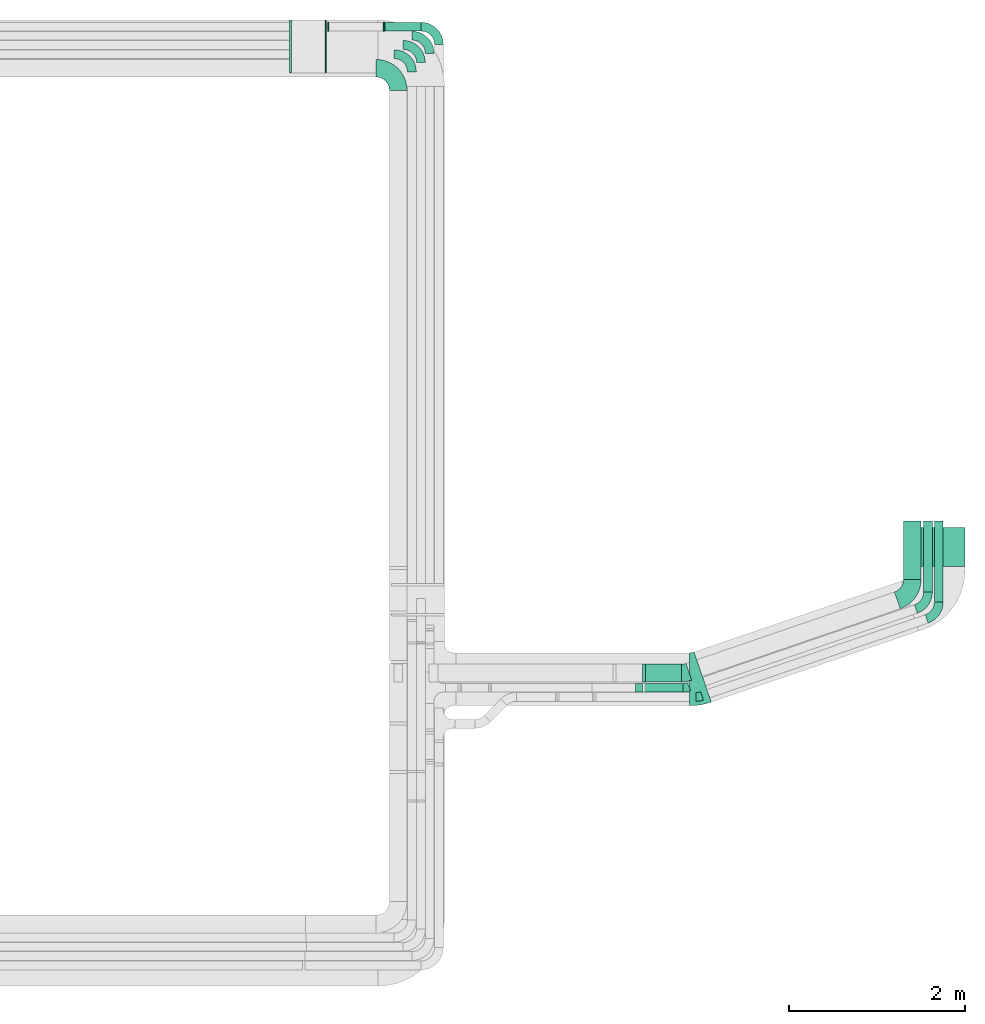
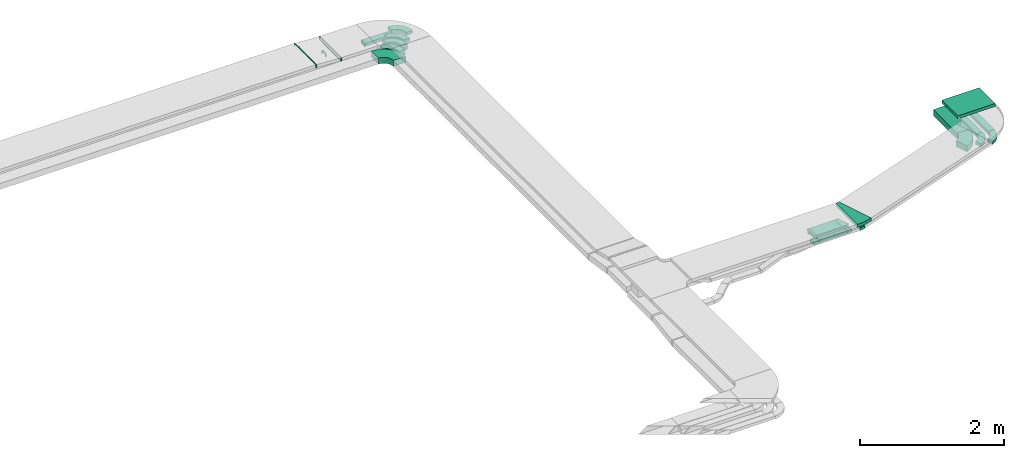
# One storey, part 24 of 28: 17 flow fittings, 8 flow segments.
"""IFC2X3 building model written with IfcOpenShell, lengths in millimetres."""

import ifcopenshell
import ifcopenshell.guid

model = None  # the IFC model being written
_history = None  # IfcOwnerHistory: only IFC2X3 demands one
_inside = {}  # id of a spatial element -> (the spatial element, [elements in it])
_under = {}  # id of a project, library or spatial element -> (it, [spatial elements below it])
_declared = {}  # id of a project -> (the project, [libraries it declares])
_typed = {}  # id of a type object -> (the type object, [elements of that type])
_made_of = {}  # id of a material, layer set ... -> (it, [elements and type objects made of it])


def new_model(schema):
    """Start an empty IFC model of exactly this schema.

    Asked for "IFC4X3", IfcOpenShell would pick the latest addendum, in which some entities
    have other attributes; the version numbers below select the first issue.
    IFC2X3 requires an IfcOwnerHistory on every rooted entity: one is made here for all.
    """
    global model, _history
    if schema == "IFC4X3":
        model = ifcopenshell.file(schema_version=(4, 3, 0, 0))
    else:
        model = ifcopenshell.file(schema=schema)
    _inside.clear()
    _under.clear()
    _declared.clear()
    _typed.clear()
    _made_of.clear()
    _history = None
    if model.schema == "IFC2X3":
        org = make("IfcOrganization", Name="unknown")
        user = make(
            "IfcPersonAndOrganization",
            ThePerson=make("IfcPerson", FamilyName="unknown"),
            TheOrganization=org,
        )
        app = make(
            "IfcApplication",
            ApplicationDeveloper=org,
            Version="unknown",
            ApplicationFullName="unknown",
            ApplicationIdentifier="unknown",
        )
        _history = make(
            "IfcOwnerHistory",
            OwningUser=user,
            OwningApplication=app,
            ChangeAction="ADDED",
            CreationDate=0,
        )
    return model


def make(cls, **values):
    """One entity of the class cls with the attributes given. An attribute that is None is left unset."""
    return model.create_entity(
        cls, **{name: value for name, value in values.items() if value is not None}
    )


def entity(cls, *values):
    """Any entity or typed value of the class cls, its attributes in the order of the schema. None: left unset."""
    e = model.create_entity(cls)
    for i, value in enumerate(values):
        if value is not None:
            e[i] = value
    return e


def rooted(cls, **values):
    """An entity with a GlobalId (a new one), such as an element, a storey or a relation."""
    return make(cls, GlobalId=ifcopenshell.guid.new(), OwnerHistory=_history, **values)


def si_unit(unit_type, name, prefix=None):
    """IfcSIUnit, for example si_unit("LENGTHUNIT", "METRE", prefix="MILLI")."""
    return make("IfcSIUnit", UnitType=unit_type, Prefix=prefix, Name=name)


def converted_unit(unit_type, name, factor, base, dimensions=None, offset=None):
    """IfcConversionBasedUnit, such as the inch: factor (a typed value) times the base unit."""
    return make(
        "IfcConversionBasedUnit"
        if offset is None
        else "IfcConversionBasedUnitWithOffset",
        ConversionOffset=offset,
        Dimensions=None
        if dimensions is None
        else entity("IfcDimensionalExponents", *dimensions),
        UnitType=unit_type,
        Name=name,
        ConversionFactor=make(
            "IfcMeasureWithUnit", ValueComponent=factor, UnitComponent=base
        ),
    )


def derived_unit(unit_type, elements):
    """IfcDerivedUnit: a product of units, each with its exponent."""
    return make(
        "IfcDerivedUnit",
        Elements=[
            make("IfcDerivedUnitElement", Unit=unit, Exponent=power)
            for unit, power in elements
        ],
        UnitType=unit_type,
    )


def assignment(units):
    """IfcUnitAssignment: the units of a project."""
    return None if units is None else make("IfcUnitAssignment", Units=units)


def point(xyz):
    """IfcCartesianPoint."""
    return None if xyz is None else make("IfcCartesianPoint", Coordinates=xyz)


def direction(xyz):
    """IfcDirection."""
    return None if xyz is None else make("IfcDirection", DirectionRatios=xyz)


def frame(location, z_axis=None, x_axis=None):
    """IfcAxis2Placement3D, a coordinate frame: its origin and axes. An axis left out is left unset."""
    return make(
        "IfcAxis2Placement3D",
        Location=point(location),
        Axis=direction(z_axis),
        RefDirection=direction(x_axis),
    )


def frame_2d(location, x_axis=None):
    """IfcAxis2Placement2D, a coordinate frame in the plane: its origin and x axis."""
    return make(
        "IfcAxis2Placement2D", Location=point(location), RefDirection=direction(x_axis)
    )


def origin():
    """The frame at (0, 0, 0) with its axes left unset."""
    return frame((0.0, 0.0, 0.0))


def origin_2d_with_axis():
    """The frame at (0, 0) in the plane with the x axis (1, 0) written out."""
    return frame_2d((0.0, 0.0), x_axis=(1.0, 0.0))


def place(relative_to, where):
    """IfcLocalPlacement: puts the frame where relative to a parent placement (None: the world)."""
    return make(
        "IfcLocalPlacement", PlacementRelTo=relative_to, RelativePlacement=where
    )


def context(
    kind, dimensions, precision=None, world=None, true_north=None, identifier=None
):
    """IfcGeometricRepresentationContext, for example the 3D "Model" context."""
    return make(
        "IfcGeometricRepresentationContext",
        ContextIdentifier=identifier,
        ContextType=kind,
        CoordinateSpaceDimension=dimensions,
        Precision=precision,
        WorldCoordinateSystem=world,
        TrueNorth=true_north,
    )


def subcontext(parent, identifier, kind, view, scale=None):
    """IfcGeometricRepresentationSubContext, for example "Body" below "Model"."""
    return make(
        "IfcGeometricRepresentationSubContext",
        ContextIdentifier=identifier,
        ContextType=kind,
        ParentContext=parent,
        TargetScale=scale,
        TargetView=view,
    )


def project(units=None, contexts=None):
    """IfcProject with its units and contexts."""
    return rooted(
        "IfcProject",
        Name="project",
        RepresentationContexts=contexts,
        UnitsInContext=assignment(units),
    )


def spatial(cls, under=None, at=None, **own):
    """A site, building, storey or space (cls), placed at a placement, below another one or the project."""
    s = rooted(cls, ObjectPlacement=at, **own)
    if under is not None:
        _under.setdefault(under.id(), (under, []))[1].append(s)
    return s


def polyline(points):
    """IfcPolyline through the points."""
    return make("IfcPolyline", Points=[point(p) for p in points])


def circle_curve(where, radius):
    """IfcCircle in the frame where."""
    return make("IfcCircle", Position=where, Radius=radius)


def parameter(value):
    """IfcParameterValue: where a trimmed curve begins or ends, as a parameter of its basis curve."""
    return model.create_entity("IfcParameterValue", value)


def trimmed(basis, trim1, trim2, sense, master):
    """IfcTrimmedCurve: the piece of a basis curve between two trims."""
    return make(
        "IfcTrimmedCurve",
        BasisCurve=basis,
        Trim1=trim1,
        Trim2=trim2,
        SenseAgreement=sense,
        MasterRepresentation=master,
    )


def segment(curve, same_sense, transition):
    """IfcCompositeCurveSegment."""
    return make(
        "IfcCompositeCurveSegment",
        Transition=transition,
        SameSense=same_sense,
        ParentCurve=curve,
    )


def composite_curve(segments, self_intersect=None):
    """IfcCompositeCurve: segments joined end to end."""
    return make("IfcCompositeCurve", Segments=segments, SelfIntersect=self_intersect)


def profile(cls, at=None, kind="AREA", **sizes):
    """A parametric profile (cls). Its sizes go by their IFC names, for example OverallWidth=200.0."""
    return make(cls, ProfileType=kind, Position=at, **sizes)


def rectangle(**sizes):
    """IfcRectangleProfileDef."""
    return profile("IfcRectangleProfileDef", **sizes)


def outline(outer, holes=None, kind="AREA"):
    """IfcArbitraryClosedProfileDef: a profile drawn as a closed curve; with holes, ...WithVoids."""
    if holes is None:
        return make("IfcArbitraryClosedProfileDef", ProfileType=kind, OuterCurve=outer)
    return make(
        "IfcArbitraryProfileDefWithVoids",
        ProfileType=kind,
        OuterCurve=outer,
        InnerCurves=holes,
    )


def extrude(swept, where, along, depth):
    """IfcExtrudedAreaSolid: the profile swept, set in the frame where, extruded along a direction by depth."""
    return make(
        "IfcExtrudedAreaSolid",
        SweptArea=swept,
        Position=where,
        ExtrudedDirection=direction(along),
        Depth=depth,
    )


def faces_of(points, faces, orient=None, outer=None):
    """IfcFace entities. A face is a list of loops; a loop is a list of indices into points, from 0.

    orient and outer hold one flag for each loop. By default every Orientation is true, the
    first loop of a face is its IfcFaceOuterBound and the others are IfcFaceBound.
    """
    made = []
    for i, loops in enumerate(faces):
        bounds = []
        for j, loop in enumerate(loops):
            is_outer = j == 0 if outer is None else outer[i][j]
            bounds.append(
                make(
                    "IfcFaceOuterBound" if is_outer else "IfcFaceBound",
                    Bound=make("IfcPolyLoop", Polygon=[points[k] for k in loop]),
                    Orientation=True if orient is None else orient[i][j],
                )
            )
        made.append(make("IfcFace", Bounds=bounds))
    return made


def faceted_brep(points, faces, orient=None, outer=None, voids=None):
    """IfcFacetedBrep: a solid bounded by flat faces; with voids (closed shells), ...WithVoids."""
    shared = [point(p) for p in points]
    hull = make("IfcClosedShell", CfsFaces=faces_of(shared, faces, orient, outer))
    if voids is None:
        return make("IfcFacetedBrep", Outer=hull)
    return make(
        "IfcFacetedBrepWithVoids",
        Outer=hull,
        Voids=[
            make(cls, CfsFaces=faces_of(shared, fs, o, b)) for cls, fs, o, b in voids
        ],
    )


def shape(context_of_items, identifier, shape_type, items):
    """IfcShapeRepresentation: the items that make up one representation, for example the "Body"."""
    return make(
        "IfcShapeRepresentation",
        ContextOfItems=context_of_items,
        RepresentationIdentifier=identifier,
        RepresentationType=shape_type,
        Items=items,
    )


def source(mapping_origin, context_of_items, identifier, shape_type, items):
    """IfcRepresentationMap: a shape defined once, which mapped items show again and again."""
    return make(
        "IfcRepresentationMap",
        MappingOrigin=mapping_origin,
        MappedRepresentation=shape(context_of_items, identifier, shape_type, items),
    )


def transform(
    local_origin,
    x_axis=None,
    y_axis=None,
    z_axis=None,
    scale=None,
    scale2=None,
    scale3=None,
    uniform=True,
):
    """IfcCartesianTransformationOperator3D, or its non-uniform kind. x_axis, y_axis, z_axis: its Axis1, 2, 3."""
    if uniform:
        return make(
            "IfcCartesianTransformationOperator3D",
            Axis1=direction(x_axis),
            Axis2=direction(y_axis),
            LocalOrigin=point(local_origin),
            Scale=scale,
            Axis3=direction(z_axis),
        )
    return make(
        "IfcCartesianTransformationOperator3DnonUniform",
        Axis1=direction(x_axis),
        Axis2=direction(y_axis),
        LocalOrigin=point(local_origin),
        Scale=scale,
        Axis3=direction(z_axis),
        Scale2=scale2,
        Scale3=scale3,
    )


def mapped(mapping_source, mapping_target):
    """IfcMappedItem: shows the shape of a source again, moved by a transform."""
    return make(
        "IfcMappedItem", MappingSource=mapping_source, MappingTarget=mapping_target
    )


def material(Name=None, Category=None):
    """IfcMaterial."""
    return make("IfcMaterial", Name=Name, Category=Category)


def made_of(thing, what):
    """Note that an element or type object is made of a material, layer set ...; save() writes the relation."""
    if what is not None:
        _made_of.setdefault(what.id(), (what, []))[1].append(thing)
    return thing


def type_object(cls, material=None, **own):
    """A type object (cls), such as IfcWallType, which elements share."""
    return made_of(rooted(cls, **own), material)


def type_shapes(of_type, sources):
    """Give a type object the sources (RepresentationMaps) that its elements show as mapped items."""
    of_type.RepresentationMaps = sources


def element(
    cls,
    number,
    at=None,
    inside=None,
    cuts=None,
    type_object=None,
    material=None,
    context=None,
    identifier="Body",
    shape_type=None,
    held_by="IfcProductDefinitionShape",
    body=None,
    shapes=None,
    **own,
):
    """One element of the class cls, such as IfcWall. Its Tag is "e" and its number.

    at: its placement. inside: the storey or other place that contains it. cuts: it is an
    opening in that element (IfcRelVoidsElement). A single representation is given by context,
    identifier, shape_type and body (its items); several are given by shapes. held_by: the class
    of the entity that holds the representations. save() writes the other relations.
    """
    e = rooted(cls, Tag="e%d" % number, ObjectPlacement=at, **own)
    if body is not None:
        shapes = [shape(context, identifier, shape_type, body)]
    if shapes is not None:
        e.Representation = make(held_by, Representations=shapes)
    if inside is not None:
        _inside.setdefault(inside.id(), (inside, []))[1].append(e)
    if cuts is not None:
        rooted(
            "IfcRelVoidsElement", RelatingBuildingElement=cuts, RelatedOpeningElement=e
        )
    if type_object is not None:
        _typed.setdefault(type_object.id(), (type_object, []))[1].append(e)
    return made_of(e, material)


def aggregate(whole, parts):
    """IfcRelAggregates: a whole, such as a stair, and the parts it consists of."""
    return rooted("IfcRelAggregates", RelatingObject=whole, RelatedObjects=parts)


def save(model, path):
    """Write the relations noted so far, then the file.

    IfcRelAggregates (storeys below a building ...), IfcRelContainedInSpatialStructure (elements
    in a storey), IfcRelDefinesByType, IfcRelAssociatesMaterial and IfcRelDeclares: one each for
    every whole, place, type object, material and project.
    """
    for whole, parts in _under.values():
        aggregate(whole, parts)
    for where, things in _inside.values():
        rooted(
            "IfcRelContainedInSpatialStructure",
            RelatedElements=things,
            RelatingStructure=where,
        )
    for kind, things in _typed.values():
        rooted("IfcRelDefinesByType", RelatedObjects=things, RelatingType=kind)
    for what, things in _made_of.values():
        rooted("IfcRelAssociatesMaterial", RelatedObjects=things, RelatingMaterial=what)
    for by, libraries in _declared.values():
        rooted("IfcRelDeclares", RelatingContext=by, RelatedDefinitions=libraries)
    model.write(path)


model = new_model("IFC2X3")

# Units and contexts
model_context = context("Model", 3, precision=0.01, world=origin(), true_north=direction((6.12303176911189e-17, 1.0)))
body_context = subcontext(model_context, "Body", "Model", "MODEL_VIEW")
ifc_project = project(units=[si_unit("LENGTHUNIT", "METRE", prefix="MILLI"), si_unit("AREAUNIT", "SQUARE_METRE"), si_unit("VOLUMEUNIT", "CUBIC_METRE"), converted_unit("PLANEANGLEUNIT", "DEGREE", entity("IfcRatioMeasure", 0.0174532925199433), si_unit("PLANEANGLEUNIT", "RADIAN"), dimensions=[0, 0, 0, 0, 0, 0, 0]), si_unit("MASSUNIT", "GRAM", prefix="KILO"), derived_unit("MASSDENSITYUNIT", [(si_unit("MASSUNIT", "GRAM", prefix="KILO"), 1), (si_unit("LENGTHUNIT", "METRE"), -3)]), derived_unit("MOMENTOFINERTIAUNIT", [(si_unit("LENGTHUNIT", "METRE"), 4)]), si_unit("TIMEUNIT", "SECOND"), si_unit("FREQUENCYUNIT", "HERTZ"), si_unit("THERMODYNAMICTEMPERATUREUNIT", "DEGREE_CELSIUS"), derived_unit("THERMALTRANSMITTANCEUNIT", [(si_unit("MASSUNIT", "GRAM", prefix="KILO"), 1), (si_unit("THERMODYNAMICTEMPERATUREUNIT", "KELVIN"), -1), (si_unit("TIMEUNIT", "SECOND"), -3)]), derived_unit("VOLUMETRICFLOWRATEUNIT", [(si_unit("LENGTHUNIT", "METRE"), 3), (si_unit("TIMEUNIT", "SECOND"), -1)]), derived_unit("MASSFLOWRATEUNIT", [(si_unit("MASSUNIT", "GRAM", prefix="KILO"), 1), (si_unit("TIMEUNIT", "SECOND"), -1)]), derived_unit("ROTATIONALFREQUENCYUNIT", [(si_unit("TIMEUNIT", "SECOND"), -1)]), si_unit("ELECTRICCURRENTUNIT", "AMPERE"), si_unit("ELECTRICVOLTAGEUNIT", "VOLT"), si_unit("POWERUNIT", "WATT"), si_unit("FORCEUNIT", "NEWTON", prefix="KILO"), si_unit("ILLUMINANCEUNIT", "LUX"), si_unit("LUMINOUSFLUXUNIT", "LUMEN"), si_unit("LUMINOUSINTENSITYUNIT", "CANDELA"), derived_unit("USERDEFINED", [(si_unit("MASSUNIT", "GRAM", prefix="KILO"), -1), (si_unit("LENGTHUNIT", "METRE"), -2), (si_unit("TIMEUNIT", "SECOND"), 3), (si_unit("LUMINOUSFLUXUNIT", "LUMEN"), 1)]), derived_unit("LINEARVELOCITYUNIT", [(si_unit("LENGTHUNIT", "METRE"), 1), (si_unit("TIMEUNIT", "SECOND"), -1)]), si_unit("PRESSUREUNIT", "PASCAL"), derived_unit("USERDEFINED", [(si_unit("LENGTHUNIT", "METRE"), -2), (si_unit("MASSUNIT", "GRAM", prefix="KILO"), 1), (si_unit("TIMEUNIT", "SECOND"), -2)]), derived_unit("LINEARFORCEUNIT", [(si_unit("MASSUNIT", "GRAM", prefix="KILO"), 1), (si_unit("LENGTHUNIT", "METRE"), 1), (si_unit("TIMEUNIT", "SECOND"), -2), (si_unit("LENGTHUNIT", "METRE"), -1)]), derived_unit("PLANARFORCEUNIT", [(si_unit("MASSUNIT", "GRAM", prefix="KILO"), 1), (si_unit("LENGTHUNIT", "METRE"), 1), (si_unit("TIMEUNIT", "SECOND"), -2), (si_unit("LENGTHUNIT", "METRE"), -2)])], contexts=[model_context])

# Site, building, storey
site_placement = place(None, origin())
site = spatial("IfcSite", under=ifc_project, at=site_placement, CompositionType="ELEMENT")
building_placement = place(site_placement, origin())
building = spatial("IfcBuilding", under=site, at=building_placement, CompositionType="ELEMENT")
storey_placement = place(building_placement, frame((0.0, 0.0, 4200.0)))
storey = spatial("IfcBuildingStorey", under=building, at=storey_placement, CompositionType="ELEMENT", Elevation=4200.0)

# Flow segments
cable_carrier_segment_type = type_object("IfcCableCarrierSegmentType", PredefinedType="CABLETRAYSEGMENT")
flow_segment_1_placement = place(storey_placement, frame((67394.03, 9970.3, 2859.5)))
element("IfcFlowSegment", 1, at=flow_segment_1_placement, inside=storey, type_object=cable_carrier_segment_type, context=body_context, shape_type="SweptSolid", body=[
    extrude(rectangle(XDim=443.027180218431, YDim=600.000000000002, at=origin_2d_with_axis()), frame((300.0, 221.51, 0.0), z_axis=(0.0, 0.0, 1.0), x_axis=(0.0, 1.0, 0.0)), (0.0, 0.0, 1.0), 50.0000000000005),
])
flow_segment_2_placement = place(storey_placement, frame((61417.21, 16039.18, 2500.0)))
element("IfcFlowSegment", 2, at=flow_segment_2_placement, inside=storey, type_object=cable_carrier_segment_type, context=body_context, shape_type="SweptSolid", body=[
    extrude(rectangle(XDim=422.974945905387, YDim=99.9999999999989, at=origin_2d_with_axis()), frame((211.49, 50.0, 0.0), z_axis=(0.0, 0.0, 1.0), x_axis=(-1.0, 0.0, 0.0)), (0.0, 0.0, 1.0), 49.9999999999995),
])
flow_segment_3_placement = place(storey_placement, frame((67298.26, 9825.03, 2637.16)))
element("IfcFlowSegment", 3, at=flow_segment_3_placement, inside=storey, type_object=cable_carrier_segment_type, context=body_context, shape_type="SweptSolid", body=[
    extrude(rectangle(XDim=660.390144086837, YDim=200.000000000007, at=origin_2d_with_axis()), frame((100.0, 330.2, 0.0), z_axis=(0.0, 0.0, 1.0), x_axis=(0.0, 1.0, 0.0)), (0.0, 0.0, 1.0), 99.9999999999978),
])
flow_segment_4_placement = place(storey_placement, frame((67525.83, 9680.21, 2683.28)))
element("IfcFlowSegment", 4, at=flow_segment_4_placement, inside=storey, type_object=cable_carrier_segment_type, context=body_context, shape_type="SweptSolid", body=[
    extrude(rectangle(XDim=805.217820192026, YDim=99.9999999999946, at=origin_2d_with_axis()), frame((50.0, 402.61, 0.0), z_axis=(0.0, 0.0, 1.0), x_axis=(0.0, 1.0, 0.0)), (0.0, 0.0, 1.0), 49.9999999999984),
])
flow_segment_5_placement = place(storey_placement, frame((67647.87, 9567.84, 2750.04)))
element("IfcFlowSegment", 5, at=flow_segment_5_placement, inside=storey, type_object=cable_carrier_segment_type, context=body_context, shape_type="SweptSolid", body=[
    extrude(rectangle(XDim=919.515278080052, YDim=99.9999999999426, at=origin_2d_with_axis()), frame((50.0, 459.76, 0.0), z_axis=(0.0, -1.12023218885433e-06, 1.0), x_axis=(0.0, 1.0, 1.12023218885433e-06)), (0.0, 0.0, 1.0), 49.999999999968),
])
flow_segment_6_placement = place(storey_placement, frame((64362.98, 8547.44, 2683.27)))
element("IfcFlowSegment", 6, at=flow_segment_6_placement, inside=storey, type_object=cable_carrier_segment_type, context=body_context, shape_type="SweptSolid", body=[
    extrude(rectangle(XDim=100.000000000001, YDim=438.35134819234, at=frame_2d((0.0, 0.0), x_axis=(0.0, 1.0))), frame((219.18, 50.01, 0.02), z_axis=(4.88705511740176e-05, -0.000142633733288134, 0.999999988633644), x_axis=(-1.0, 0.0, 4.88705516711381e-05)), (0.0, 0.0, 1.0), 50.0000000000004),
])
flow_segment_7_placement = place(storey_placement, frame((64374.07, 8663.79, 2637.16)))
element("IfcFlowSegment", 7, at=flow_segment_7_placement, inside=storey, type_object=cable_carrier_segment_type, context=body_context, shape_type="SweptSolid", body=[
    extrude(rectangle(XDim=408.398049155987, YDim=200.0, at=origin_2d_with_axis()), frame((204.2, 100.0, 0.0), z_axis=(0.0, 0.0, 1.0), x_axis=(-1.0, 0.0, 0.0)), (0.0, 0.0, 1.0), 99.9999999999989),
])
flow_segment_8_placement = place(storey_placement, frame((64258.91, 8547.45, 2669.22)))
element("IfcFlowSegment", 8, at=flow_segment_8_placement, inside=storey, type_object=cable_carrier_segment_type, context=body_context, shape_type="SweptSolid", body=[
    extrude(rectangle(XDim=49.9999999999996, YDim=82.6344223697702, at=frame_2d((0.0, 0.0), x_axis=(0.0, 1.0))), frame((44.72, 0.0, 31.16), z_axis=(0.0, 1.0, 0.0), x_axis=(-0.98768834059514, 0.0, -0.156434465040215)), (0.0, 0.0, 1.0), 100.000000000001),
])

# Flow fittings
ifc_material = material()
cable_carrier_fitting_type_1 = type_object("IfcCableCarrierFittingType", PredefinedType="NOTDEFINED", material=ifc_material)
shared_shape_1 = source(origin(), body_context, "Body", "Brep", [
    faceted_brep([(-6.7, -25.0, 300.0), (-6.7, 25.0, 300.0), (-6.7, 25.0, 297.46), (-6.7, -22.46, 297.46), (-6.7, -22.46, -297.46), (-6.7, 25.0, -297.46), (-6.7, 25.0, -300.0), (-6.7, -25.0, -300.0), (8.23, -24.54, 300.0), (8.23, -24.54, -300.0), (5.14, 25.37, -300.0), (5.14, 25.37, -297.46), (8.07, -22.0, -297.46), (8.07, -22.0, 297.46), (5.14, 25.37, 297.46), (5.14, 25.37, 300.0), (0.77, -25.0, 300.0), (-0.77, 25.0, 300.0), (-0.77, 25.0, 297.46), (0.69, -22.46, 297.46), (0.69, -22.46, -297.46), (-0.77, 25.0, -297.46), (-0.77, 25.0, -300.0), (0.77, -25.0, -300.0)], [[[0, 1, 2, 3, 4, 5, 6, 7]], [[8, 9, 10, 11, 12, 13, 14, 15]], [[1, 0, 16, 8, 15, 17]], [[2, 1, 17, 18]], [[3, 2, 18, 14, 13, 19]], [[4, 3, 19, 20]], [[5, 4, 20, 12, 11, 21]], [[6, 5, 21, 22]], [[7, 6, 22, 10, 9, 23]], [[0, 7, 23, 16]], [[18, 17, 15, 14]], [[20, 19, 13, 12]], [[22, 21, 11, 10]], [[16, 23, 9, 8]]]),
])
type_shapes(cable_carrier_fitting_type_1, [shared_shape_1])
for number, where, z_axis, x_axis in (
    (9, (60751.24, 15866.15, 2798.4), (0.0, 1.0, 0.0), (-1.0, 0.0, 0.0)),
    (10, (60350.54, 15866.15, 2823.17), (0.0, -1.0, 0.0), (-0.998094861417354, 0.0, 0.0616980357245895)),
):
    element("IfcFlowFitting", number, at=place(storey_placement, frame(where, z_axis=z_axis, x_axis=x_axis)), inside=storey, type_object=cable_carrier_fitting_type_1, material=ifc_material, context=body_context, shape_type="MappedRepresentation", body=[
        mapped(shared_shape_1, transform((0.0, 0.0, 0.0), scale=1.0)),
    ])
cable_carrier_fitting_type_2 = type_object("IfcCableCarrierFittingType", PredefinedType="NOTDEFINED", material=ifc_material)
shared_shape_2 = source(origin(), body_context, "Body", "Brep", [
    faceted_brep([(-13.26, -50.0, 100.0), (-13.26, 50.0, 100.0), (-13.26, 50.0, 97.46), (-13.26, -47.46, 97.46), (-13.26, -47.46, -97.46), (-13.26, 50.0, -97.46), (-13.26, 50.0, -100.0), (-13.26, -50.0, -100.0), (20.92, -47.31, 100.0), (20.92, -47.31, -100.0), (5.28, 51.46, -100.0), (5.28, 51.46, -97.46), (20.52, -44.8, -97.46), (20.52, -44.8, 97.46), (5.28, 51.46, 97.46), (5.28, 51.46, 100.0), (3.94, -50.0, 100.0), (-3.94, 50.0, 100.0), (-3.94, 50.0, 97.46), (3.74, -47.46, 97.46), (3.74, -47.46, -97.46), (-3.94, 50.0, -97.46), (-3.94, 50.0, -100.0), (3.94, -50.0, -100.0)], [[[0, 1, 2, 3, 4, 5, 6, 7]], [[8, 9, 10, 11, 12, 13, 14, 15]], [[1, 0, 16, 8, 15, 17]], [[2, 1, 17, 18]], [[3, 2, 18, 14, 13, 19]], [[4, 3, 19, 20]], [[5, 4, 20, 12, 11, 21]], [[6, 5, 21, 22]], [[7, 6, 22, 10, 9, 23]], [[0, 7, 23, 16]], [[18, 17, 15, 14]], [[20, 19, 13, 12]], [[22, 21, 11, 10]], [[16, 23, 9, 8]]]),
])
type_shapes(cable_carrier_fitting_type_2, [shared_shape_2])
flow_fitting_1_placement = place(storey_placement, frame((64360.81, 8763.79, 2687.16), z_axis=(0.0, -1.0, 0.0), x_axis=(-1.0, 0.0, 0.0)))
element("IfcFlowFitting", 11, at=flow_fitting_1_placement, inside=storey, type_object=cable_carrier_fitting_type_2, material=ifc_material, context=body_context, shape_type="MappedRepresentation", body=[
    mapped(shared_shape_2, transform((0.0, 0.0, 0.0), scale=1.0)),
])
cable_carrier_fitting_type_3 = type_object("IfcCableCarrierFittingType", PredefinedType="NOTDEFINED", material=ifc_material)
shared_shape_3 = source(origin(), body_context, "Body", "Brep", [
    faceted_brep([(-7.03, -25.0, 50.0), (-7.03, 25.0, 50.0), (-7.03, 25.0, 47.46), (-7.03, -22.46, 47.46), (-7.03, -22.46, -47.46), (-7.03, 25.0, -47.46), (-7.03, 25.0, -50.0), (-7.03, -25.0, -50.0), (8.84, -24.42, 50.0), (8.84, -24.42, -50.0), (5.17, 25.45, -50.0), (5.17, 25.45, -47.46), (8.66, -21.88, -47.46), (8.66, -21.88, 47.46), (5.17, 25.45, 47.46), (5.17, 25.45, 50.0), (0.92, -25.0, 50.0), (-0.92, 25.0, 50.0), (-0.92, 25.0, 47.46), (0.83, -22.46, 47.46), (0.83, -22.46, -47.46), (-0.92, 25.0, -47.46), (-0.92, 25.0, -50.0), (0.92, -25.0, -50.0)], [[[0, 1, 2, 3, 4, 5, 6, 7]], [[8, 9, 10, 11, 12, 13, 14, 15]], [[1, 0, 16, 8, 15, 17]], [[2, 1, 17, 18]], [[3, 2, 18, 14, 13, 19]], [[4, 3, 19, 20]], [[5, 4, 20, 12, 11, 21]], [[6, 5, 21, 22]], [[7, 6, 22, 10, 9, 23]], [[0, 7, 23, 16]], [[18, 17, 15, 14]], [[20, 19, 13, 12]], [[22, 21, 11, 10]], [[16, 23, 9, 8]]]),
])
type_shapes(cable_carrier_fitting_type_3, [shared_shape_3])
for number, where, z_axis, x_axis in (
    (12, (60776.78, 16089.18, 2571.71), (0.0, 1.0, 0.0), (1.0, 0.0, 0.0)),
    (13, (61410.18, 16089.18, 2525.0), (0.0, 1.0, 0.0), (-1.0, 0.0, 0.0)),
):
    element("IfcFlowFitting", number, at=place(storey_placement, frame(where, z_axis=z_axis, x_axis=x_axis)), inside=storey, type_object=cable_carrier_fitting_type_3, material=ifc_material, context=body_context, shape_type="MappedRepresentation", body=[
        mapped(shared_shape_3, transform((0.0, 0.0, 0.0), scale=1.0)),
    ])
cable_carrier_fitting_type_4 = type_object("IfcCableCarrierFittingType", Name="470_DKC_S5_Variable Angle Elbow 0-45:-", PredefinedType="NOTDEFINED", material=ifc_material)
shared_shape_4 = source(origin(), body_context, "Body", "SweptSolid", [
    extrude(outline(composite_curve([segment(polyline([(-125.75, -225.25), (-124.75, -225.25)]), True, "CONTINUOUS"), segment(trimmed(circle_curve(frame_2d((-124.75, 124.75), x_axis=(0.0, -1.0)), 350.0), [parameter(0.0)], [parameter(90.0000000000001)], True, "PARAMETER"), True, "CONTINUOUS"), segment(polyline([(225.25, 124.75), (225.25, 125.75)]), True, "CONTINUOUS"), segment(polyline([(225.25, 125.75), (25.25, 125.75)]), True, "CONTINUOUS"), segment(polyline([(25.25, 125.75), (25.25, 124.75)]), True, "CONTINUOUS"), segment(trimmed(circle_curve(frame_2d((-124.75, 124.75), x_axis=(0.0, -1.0)), 150.0), [parameter(0.0)], [parameter(90.0000000000001)], True, "PARAMETER"), False, "CONTINUOUS"), segment(polyline([(-124.75, -25.25), (-125.75, -25.25)]), True, "CONTINUOUS"), segment(polyline([(-125.75, -25.25), (-125.75, -225.25)]), True, "CONTINUOUS")], self_intersect=False)), frame((-125.25, 125.25, -50.0)), (0.0, 0.0, 1.0), 100.0),
])
type_shapes(cable_carrier_fitting_type_4, [shared_shape_4])
flow_fitting_2_placement = place(storey_placement, frame((61571.18, 15619.49, 2596.2), z_axis=(0.00228023645944123, 0.0, 0.999997400257465), x_axis=(0.0, 1.0, 0.0)))
element("IfcFlowFitting", 14, at=flow_fitting_2_placement, inside=storey, type_object=cable_carrier_fitting_type_4, material=ifc_material, Name="470_DKC_S5_Variable Angle Elbow 0-45:-", ObjectType="470_DKC_S5_Variable Angle Elbow 0-45:-", context=body_context, shape_type="MappedRepresentation", body=[
    mapped(shared_shape_4, transform((0.0, 0.0, 0.0), scale=1.0)),
])
cable_carrier_fitting_type_5 = type_object("IfcCableCarrierFittingType", Name="470_DKC_S5_Variable Angle Elbow 0-45:-", PredefinedType="NOTDEFINED", material=ifc_material)
shared_shape_5 = source(origin(), body_context, "Body", "SweptSolid", [
    extrude(outline(composite_curve([segment(polyline([(-100.75, -150.25), (-99.75, -150.25)]), True, "CONTINUOUS"), segment(trimmed(circle_curve(frame_2d((-99.75, 99.75), x_axis=(0.0, -1.0)), 250.0), [parameter(0.0)], [parameter(90.0000000000001)], True, "PARAMETER"), True, "CONTINUOUS"), segment(polyline([(150.25, 99.75), (150.25, 100.75)]), True, "CONTINUOUS"), segment(polyline([(150.25, 100.75), (50.25, 100.75)]), True, "CONTINUOUS"), segment(polyline([(50.25, 100.75), (50.25, 99.75)]), True, "CONTINUOUS"), segment(trimmed(circle_curve(frame_2d((-99.75, 99.75), x_axis=(0.0, -1.0)), 150.0), [parameter(0.0)], [parameter(90.0000000000001)], True, "PARAMETER"), False, "CONTINUOUS"), segment(polyline([(-99.75, -50.25), (-100.75, -50.25)]), True, "CONTINUOUS"), segment(polyline([(-100.75, -50.25), (-100.75, -150.25)]), True, "CONTINUOUS")], self_intersect=False)), frame((-100.25, 100.25, -25.0)), (0.0, 0.0, 1.0), 49.9999999999997),
])
type_shapes(cable_carrier_fitting_type_5, [shared_shape_5])
for number, where, z_axis, x_axis, name in (
    (15, (62032.18, 16089.18, 2602.31), (0.0, 0.0, 1.0), (0.0, 1.0, 0.0), "470_DKC_S5_Variable Angle Elbow 0-45:-"),
    (16, (61928.34, 15988.42, 2571.7), (0.0, 0.0, 1.0), (0.0, 1.0, 0.0), "470_DKC_S5_Variable Angle Elbow 0-45:-"),
):
    element("IfcFlowFitting", number, at=place(storey_placement, frame(where, z_axis=z_axis, x_axis=x_axis)), inside=storey, type_object=cable_carrier_fitting_type_5, material=ifc_material, Name=name, ObjectType="470_DKC_S5_Variable Angle Elbow 0-45:-", context=body_context, shape_type="MappedRepresentation", body=[
        mapped(shared_shape_5, transform((0.0, 0.0, 0.0), scale=1.0)),
    ])
cable_carrier_fitting_type_6 = type_object("IfcCableCarrierFittingType", Name="470_DKC_S5_Variable Angle Elbow 0-45:-", PredefinedType="NOTDEFINED", material=ifc_material)
shared_shape_6 = source(origin(), body_context, "Body", "SweptSolid", [
    extrude(outline(composite_curve([segment(polyline([(-100.75, -150.25), (-99.75, -150.25)]), True, "CONTINUOUS"), segment(trimmed(circle_curve(frame_2d((-99.75, 99.75), x_axis=(0.0, -1.0)), 250.0), [parameter(0.0)], [parameter(90.0000000000001)], True, "PARAMETER"), True, "CONTINUOUS"), segment(polyline([(150.25, 99.75), (150.25, 100.75)]), True, "CONTINUOUS"), segment(polyline([(150.25, 100.75), (50.25, 100.75)]), True, "CONTINUOUS"), segment(polyline([(50.25, 100.75), (50.25, 99.75)]), True, "CONTINUOUS"), segment(trimmed(circle_curve(frame_2d((-99.75, 99.75), x_axis=(0.0, -1.0)), 150.0), [parameter(0.0)], [parameter(90.0000000000001)], True, "PARAMETER"), False, "CONTINUOUS"), segment(polyline([(-99.75, -50.25), (-100.75, -50.25)]), True, "CONTINUOUS"), segment(polyline([(-100.75, -50.25), (-100.75, -150.25)]), True, "CONTINUOUS")], self_intersect=False)), frame((-100.25, 100.25, -50.0)), (0.0, 0.0, 1.0), 100.0),
])
type_shapes(cable_carrier_fitting_type_6, [shared_shape_6])
for number, where, z_axis, x_axis, name in (
    (17, (61726.28, 15778.42, 2553.42), (0.00225764146350653, 0.0, 0.999997451524264), (0.0, 1.0, 0.0), "470_DKC_S5_Variable Angle Elbow 0-45:-"),
    (18, (61828.68, 15883.42, 2553.44), (0.0, 0.0, 1.0), (0.0, 1.0, 0.0), "470_DKC_S5_Variable Angle Elbow 0-45:-"),
):
    element("IfcFlowFitting", number, at=place(storey_placement, frame(where, z_axis=z_axis, x_axis=x_axis)), inside=storey, type_object=cable_carrier_fitting_type_6, material=ifc_material, Name=name, ObjectType="470_DKC_S5_Variable Angle Elbow 0-45:-", context=body_context, shape_type="MappedRepresentation", body=[
        mapped(shared_shape_6, transform((0.0, 0.0, 0.0), scale=1.0)),
    ])
cable_carrier_fitting_type_7 = type_object("IfcCableCarrierFittingType", Name="470_DKC_S5_Variable Angle Elbow 0-45:-", PredefinedType="NOTDEFINED", material=ifc_material)
shared_shape_7 = source(origin(), body_context, "Body", "SweptSolid", [
    extrude(outline(composite_curve([segment(polyline([(-95.43, -117.82), (-94.43, -117.82)]), True, "CONTINUOUS"), segment(trimmed(circle_curve(frame_2d((-94.43, 132.18), x_axis=(0.0, -1.0)), 250.0), [parameter(0.0)], [parameter(71.0870179252923)], True, "PARAMETER"), True, "CONTINUOUS"), segment(polyline([(142.07, 51.14), (142.39, 52.09)]), True, "CONTINUOUS"), segment(polyline([(142.39, 52.09), (47.79, 84.5)]), True, "CONTINUOUS"), segment(polyline([(47.79, 84.5), (47.47, 83.56)]), True, "CONTINUOUS"), segment(trimmed(circle_curve(frame_2d((-94.43, 132.18), x_axis=(0.0, -1.0)), 150.0), [parameter(0.0)], [parameter(71.0870179252923)], True, "PARAMETER"), False, "CONTINUOUS"), segment(polyline([(-94.43, -17.82), (-95.43, -17.82)]), True, "CONTINUOUS"), segment(polyline([(-95.43, -17.82), (-95.43, -117.82)]), True, "CONTINUOUS")], self_intersect=False)), frame((-48.46, 67.82, -25.0)), (0.0, 0.0, 1.0), 49.9999999999998),
])
type_shapes(cable_carrier_fitting_type_7, [shared_shape_7])
for number, where, z_axis, x_axis, name in (
    (19, (67575.83, 9536.32, 2708.28), (0.0, 0.0, 1.0), (0.946011941351311, 0.324131773852432, 0.0), "470_DKC_S5_Variable Angle Elbow 0-45:-"),
    (20, (67697.87, 9423.95, 2775.04), (0.0, 0.0, 1.0), (0.946011941351311, 0.324131773852432, 0.0), "470_DKC_S5_Variable Angle Elbow 0-45:-"),
):
    element("IfcFlowFitting", number, at=place(storey_placement, frame(where, z_axis=z_axis, x_axis=x_axis)), inside=storey, type_object=cable_carrier_fitting_type_7, material=ifc_material, Name=name, ObjectType="470_DKC_S5_Variable Angle Elbow 0-45:-", context=body_context, shape_type="MappedRepresentation", body=[
        mapped(shared_shape_7, transform((0.0, 0.0, 0.0), scale=1.0)),
    ])
cable_carrier_fitting_type_8 = type_object("IfcCableCarrierFittingType", Name="470_DKC_S5_Variable Angle Elbow 0-45:-", PredefinedType="NOTDEFINED", material=ifc_material)
shared_shape_8 = source(origin(), body_context, "Body", "SweptSolid", [
    extrude(outline(composite_curve([segment(polyline([(-119.08, -184.72), (-118.08, -184.72)]), True, "CONTINUOUS"), segment(trimmed(circle_curve(frame_2d((-118.08, 165.28), x_axis=(0.0, -1.0)), 350.0), [parameter(0.0)], [parameter(71.0870179252923)], True, "PARAMETER"), True, "CONTINUOUS"), segment(polyline([(213.02, 51.83), (213.35, 52.78)]), True, "CONTINUOUS"), segment(polyline([(213.35, 52.78), (24.14, 117.61)]), True, "CONTINUOUS"), segment(polyline([(24.14, 117.61), (23.82, 116.66)]), True, "CONTINUOUS"), segment(trimmed(circle_curve(frame_2d((-118.08, 165.28), x_axis=(0.0, -1.0)), 150.0), [parameter(0.0)], [parameter(71.0870179252923)], True, "PARAMETER"), False, "CONTINUOUS"), segment(polyline([(-118.08, 15.28), (-119.08, 15.28)]), True, "CONTINUOUS"), segment(polyline([(-119.08, 15.28), (-119.08, -184.72)]), True, "CONTINUOUS")], self_intersect=False)), frame((-60.53, 84.72, -50.0)), (0.0, 0.0, 1.0), 100.0),
])
type_shapes(cable_carrier_fitting_type_8, [shared_shape_8])
flow_fitting_3_placement = place(storey_placement, frame((67398.26, 9645.42, 2687.16), z_axis=(0.0, 0.0, 1.0), x_axis=(0.946011941351309, 0.324131773852437, 0.0)))
element("IfcFlowFitting", 21, at=flow_fitting_3_placement, inside=storey, type_object=cable_carrier_fitting_type_8, material=ifc_material, Name="470_DKC_S5_Variable Angle Elbow 0-45:-", ObjectType="470_DKC_S5_Variable Angle Elbow 0-45:-", context=body_context, shape_type="MappedRepresentation", body=[
    mapped(shared_shape_8, transform((0.0, 0.0, 0.0), scale=1.0)),
])
cable_carrier_fitting_type_9 = type_object("IfcCableCarrierFittingType", Name="470_DKC_S5_Variable Angle Elbow 0-45:-", PredefinedType="NOTDEFINED", material=ifc_material)
shared_shape_9 = source(origin(), body_context, "Body", "SweptSolid", [
    extrude(outline(composite_curve([segment(polyline([(-41.5, -106.83), (-40.5, -106.83)]), True, "CONTINUOUS"), segment(trimmed(circle_curve(frame_2d((-40.5, 243.17), x_axis=(0.0, -1.0)), 350.0), [parameter(0.0)], [parameter(18.9129820747075)], True, "PARAMETER"), True, "CONTINUOUS"), segment(polyline([(72.94, -87.93), (73.89, -87.61)]), True, "CONTINUOUS"), segment(polyline([(73.89, -87.61), (9.06, 101.59)]), True, "CONTINUOUS"), segment(polyline([(9.06, 101.59), (8.12, 101.27)]), True, "CONTINUOUS"), segment(trimmed(circle_curve(frame_2d((-40.5, 243.17), x_axis=(0.0, -1.0)), 150.0), [parameter(0.0)], [parameter(18.9129820747075)], True, "PARAMETER"), False, "CONTINUOUS"), segment(polyline([(-40.5, 93.17), (-41.5, 93.17)]), True, "CONTINUOUS"), segment(polyline([(-41.5, 93.17), (-41.5, -106.83)]), True, "CONTINUOUS")], self_intersect=False)), frame((-1.14, 6.83, -50.0)), (0.0, 0.0, 1.0), 100.0),
])
type_shapes(cable_carrier_fitting_type_9, [shared_shape_9])
flow_fitting_4_placement = place(storey_placement, frame((64825.11, 8763.79, 2687.16)))
element("IfcFlowFitting", 22, at=flow_fitting_4_placement, inside=storey, type_object=cable_carrier_fitting_type_9, material=ifc_material, Name="470_DKC_S5_Variable Angle Elbow 0-45:-", ObjectType="470_DKC_S5_Variable Angle Elbow 0-45:-", context=body_context, shape_type="MappedRepresentation", body=[
    mapped(shared_shape_9, transform((0.0, 0.0, 0.0), scale=1.0)),
])
cable_carrier_fitting_type_10 = type_object("IfcCableCarrierFittingType", Name="470_DKC_S5_Variable Angle Elbow 0-45:-", PredefinedType="NOTDEFINED", material=ifc_material)
shared_shape_10 = source(origin(), body_context, "Body", "SweptSolid", [
    extrude(outline(composite_curve([segment(polyline([(-33.4, -55.48), (-32.4, -55.48)]), True, "CONTINUOUS"), segment(trimmed(circle_curve(frame_2d((-32.4, 194.52), x_axis=(0.0, -1.0)), 250.0), [parameter(0.0)], [parameter(18.9129822744004)], True, "PARAMETER"), True, "CONTINUOUS"), segment(polyline([(48.63, -41.98), (49.58, -41.66)]), True, "CONTINUOUS"), segment(polyline([(49.58, -41.66), (17.17, 52.94)]), True, "CONTINUOUS"), segment(polyline([(17.17, 52.94), (16.22, 52.62)]), True, "CONTINUOUS"), segment(trimmed(circle_curve(frame_2d((-32.4, 194.52), x_axis=(0.0, -1.0)), 150.0), [parameter(0.0)], [parameter(18.9129822744004)], True, "PARAMETER"), False, "CONTINUOUS"), segment(polyline([(-32.4, 44.52), (-33.4, 44.52)]), True, "CONTINUOUS"), segment(polyline([(-33.4, 44.52), (-33.4, -55.48)]), True, "CONTINUOUS")], self_intersect=False)), frame((-0.91, 5.48, -25.0)), (0.0, 0.0, 1.0), 50.0000000000001),
])
type_shapes(cable_carrier_fitting_type_10, [shared_shape_10])
flow_fitting_5_placement = place(storey_placement, frame((64835.64, 8597.45, 2708.28), z_axis=(4.88705511631072e-05, -0.000142633733284561, 0.999999988633644), x_axis=(1.0, 0.0, -4.88705516602278e-05)))
element("IfcFlowFitting", 23, at=flow_fitting_5_placement, inside=storey, type_object=cable_carrier_fitting_type_10, material=ifc_material, Name="470_DKC_S5_Variable Angle Elbow 0-45:-", ObjectType="470_DKC_S5_Variable Angle Elbow 0-45:-", context=body_context, shape_type="MappedRepresentation", body=[
    mapped(shared_shape_10, transform((0.0, 0.0, 0.0), scale=1.0)),
])
cable_carrier_fitting_type_11 = type_object("IfcCableCarrierFittingType", Name="470_DKC_S5_Variable Angle Elbow 0-45:-", PredefinedType="NOTDEFINED", material=ifc_material)
shared_shape_11 = source(origin(), body_context, "Body", "SweptSolid", [
    extrude(outline(composite_curve([segment(polyline([(-33.4, -55.48), (-32.4, -55.48)]), True, "CONTINUOUS"), segment(trimmed(circle_curve(frame_2d((-32.4, 194.52), x_axis=(0.0, -1.0)), 250.0), [parameter(0.0)], [parameter(18.9129822068405)], True, "PARAMETER"), True, "CONTINUOUS"), segment(polyline([(48.63, -41.98), (49.58, -41.66)]), True, "CONTINUOUS"), segment(polyline([(49.58, -41.66), (17.17, 52.94)]), True, "CONTINUOUS"), segment(polyline([(17.17, 52.94), (16.22, 52.62)]), True, "CONTINUOUS"), segment(trimmed(circle_curve(frame_2d((-32.4, 194.52), x_axis=(0.0, -1.0)), 150.0), [parameter(0.0)], [parameter(18.9129822068405)], True, "PARAMETER"), False, "CONTINUOUS"), segment(polyline([(-32.4, 44.52), (-33.4, 44.52)]), True, "CONTINUOUS"), segment(polyline([(-33.4, 44.52), (-33.4, -55.48)]), True, "CONTINUOUS")], self_intersect=False)), frame((-0.91, 5.48, -25.0)), (0.0, 0.0, 1.0), 50.0000000000001),
])
type_shapes(cable_carrier_fitting_type_11, [shared_shape_11])
flow_fitting_6_placement = place(storey_placement, frame((64982.4, 8493.55, 2775.04), z_axis=(3.97531317755956e-05, -0.000116023606445159, 0.999999992479106), x_axis=(1.0, 0.0, -3.97531320431636e-05)))
element("IfcFlowFitting", 24, at=flow_fitting_6_placement, inside=storey, type_object=cable_carrier_fitting_type_11, material=ifc_material, Name="470_DKC_S5_Variable Angle Elbow 0-45:-", ObjectType="470_DKC_S5_Variable Angle Elbow 0-45:-", context=body_context, shape_type="MappedRepresentation", body=[
    mapped(shared_shape_11, transform((0.0, 0.0, 0.0), scale=1.0)),
])
cable_carrier_fitting_type_12 = type_object("IfcCableCarrierFittingType", Name="470_DKC_S5_Variable Angle Elbow 0-45:-", PredefinedType="NOTDEFINED", material=ifc_material)
shared_shape_12 = source(origin(), body_context, "Body", "SweptSolid", [
    extrude(outline(composite_curve([segment(polyline([(-73.92, -312.23), (-72.92, -312.23)]), True, "CONTINUOUS"), segment(trimmed(circle_curve(frame_2d((-72.92, 437.77), x_axis=(0.0, -1.0)), 750.0), [parameter(0.0)], [parameter(18.9129820745573)], True, "PARAMETER"), True, "CONTINUOUS"), segment(polyline([(170.18, -271.74), (171.13, -271.41)]), True, "CONTINUOUS"), segment(polyline([(171.13, -271.41), (-23.35, 296.19)]), True, "CONTINUOUS"), segment(polyline([(-23.35, 296.19), (-24.3, 295.87)]), True, "CONTINUOUS"), segment(trimmed(circle_curve(frame_2d((-72.92, 437.77), x_axis=(0.0, -1.0)), 150.0), [parameter(0.0)], [parameter(18.9129820745573)], True, "PARAMETER"), False, "CONTINUOUS"), segment(polyline([(-72.92, 287.77), (-73.92, 287.77)]), True, "CONTINUOUS"), segment(polyline([(-73.92, 287.77), (-73.92, -312.23)]), True, "CONTINUOUS")], self_intersect=False)), frame((-2.04, 12.23, -25.0)), (0.0, 0.0, 1.0), 50.0000000000028),
])
type_shapes(cable_carrier_fitting_type_12, [shared_shape_12])
flow_fitting_7_placement = place(storey_placement, frame((64950.55, 8693.32, 2884.52)))
element("IfcFlowFitting", 25, at=flow_fitting_7_placement, inside=storey, type_object=cable_carrier_fitting_type_12, material=ifc_material, Name="470_DKC_S5_Variable Angle Elbow 0-45:-", ObjectType="470_DKC_S5_Variable Angle Elbow 0-45:-", context=body_context, shape_type="MappedRepresentation", body=[
    mapped(shared_shape_12, transform((0.0, 0.0, 0.0), scale=1.0)),
])

save(model, "model.ifc")
